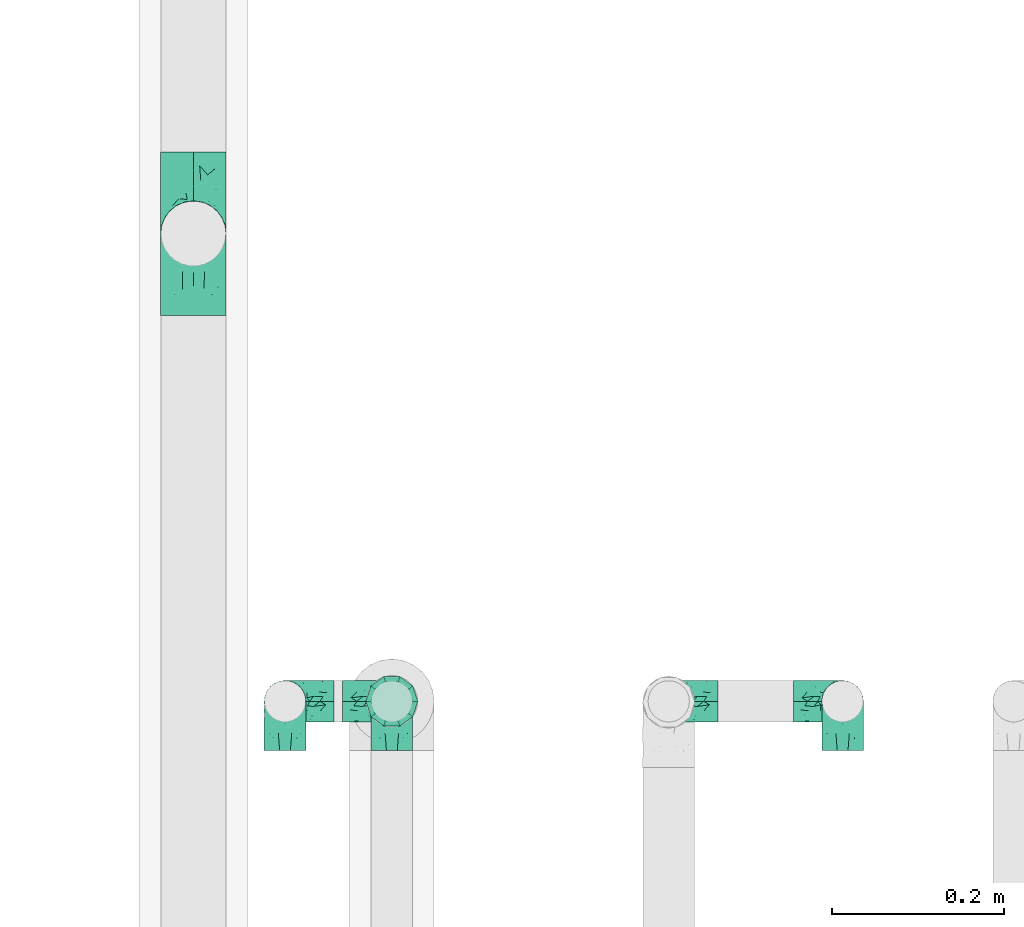
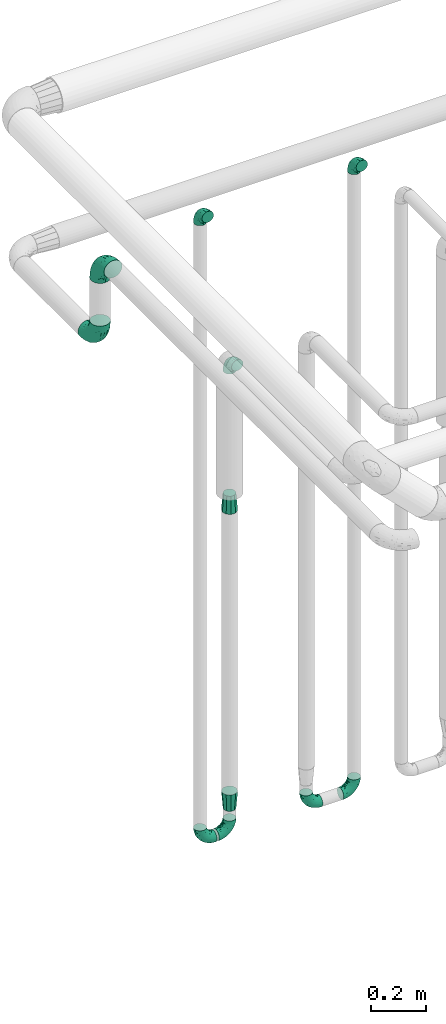
# One storey, part 697 of 827: 11 flow fittings.
"""IFC2X3 building model written with IfcOpenShell, lengths in millimetres."""

import ifcopenshell
import ifcopenshell.guid

model = None  # the IFC model being written
_history = None  # IfcOwnerHistory: only IFC2X3 demands one
_inside = {}  # id of a spatial element -> (the spatial element, [elements in it])
_under = {}  # id of a project, library or spatial element -> (it, [spatial elements below it])
_declared = {}  # id of a project -> (the project, [libraries it declares])
_typed = {}  # id of a type object -> (the type object, [elements of that type])
_made_of = {}  # id of a material, layer set ... -> (it, [elements and type objects made of it])


def new_model(schema):
    """Start an empty IFC model of exactly this schema.

    Asked for "IFC4X3", IfcOpenShell would pick the latest addendum, in which some entities
    have other attributes; the version numbers below select the first issue.
    IFC2X3 requires an IfcOwnerHistory on every rooted entity: one is made here for all.
    """
    global model, _history
    if schema == "IFC4X3":
        model = ifcopenshell.file(schema_version=(4, 3, 0, 0))
    else:
        model = ifcopenshell.file(schema=schema)
    _inside.clear()
    _under.clear()
    _declared.clear()
    _typed.clear()
    _made_of.clear()
    _history = None
    if model.schema == "IFC2X3":
        org = make("IfcOrganization", Name="unknown")
        user = make(
            "IfcPersonAndOrganization",
            ThePerson=make("IfcPerson", FamilyName="unknown"),
            TheOrganization=org,
        )
        app = make(
            "IfcApplication",
            ApplicationDeveloper=org,
            Version="unknown",
            ApplicationFullName="unknown",
            ApplicationIdentifier="unknown",
        )
        _history = make(
            "IfcOwnerHistory",
            OwningUser=user,
            OwningApplication=app,
            ChangeAction="ADDED",
            CreationDate=0,
        )
    return model


def make(cls, **values):
    """One entity of the class cls with the attributes given. An attribute that is None is left unset."""
    return model.create_entity(
        cls, **{name: value for name, value in values.items() if value is not None}
    )


def entity(cls, *values):
    """Any entity or typed value of the class cls, its attributes in the order of the schema. None: left unset."""
    e = model.create_entity(cls)
    for i, value in enumerate(values):
        if value is not None:
            e[i] = value
    return e


def rooted(cls, **values):
    """An entity with a GlobalId (a new one), such as an element, a storey or a relation."""
    return make(cls, GlobalId=ifcopenshell.guid.new(), OwnerHistory=_history, **values)


def si_unit(unit_type, name, prefix=None):
    """IfcSIUnit, for example si_unit("LENGTHUNIT", "METRE", prefix="MILLI")."""
    return make("IfcSIUnit", UnitType=unit_type, Prefix=prefix, Name=name)


def converted_unit(unit_type, name, factor, base, dimensions=None, offset=None):
    """IfcConversionBasedUnit, such as the inch: factor (a typed value) times the base unit."""
    return make(
        "IfcConversionBasedUnit"
        if offset is None
        else "IfcConversionBasedUnitWithOffset",
        ConversionOffset=offset,
        Dimensions=None
        if dimensions is None
        else entity("IfcDimensionalExponents", *dimensions),
        UnitType=unit_type,
        Name=name,
        ConversionFactor=make(
            "IfcMeasureWithUnit", ValueComponent=factor, UnitComponent=base
        ),
    )


def derived_unit(unit_type, elements):
    """IfcDerivedUnit: a product of units, each with its exponent."""
    return make(
        "IfcDerivedUnit",
        Elements=[
            make("IfcDerivedUnitElement", Unit=unit, Exponent=power)
            for unit, power in elements
        ],
        UnitType=unit_type,
    )


def assignment(units):
    """IfcUnitAssignment: the units of a project."""
    return None if units is None else make("IfcUnitAssignment", Units=units)


def point(xyz):
    """IfcCartesianPoint."""
    return None if xyz is None else make("IfcCartesianPoint", Coordinates=xyz)


def direction(xyz):
    """IfcDirection."""
    return None if xyz is None else make("IfcDirection", DirectionRatios=xyz)


def frame(location, z_axis=None, x_axis=None):
    """IfcAxis2Placement3D, a coordinate frame: its origin and axes. An axis left out is left unset."""
    return make(
        "IfcAxis2Placement3D",
        Location=point(location),
        Axis=direction(z_axis),
        RefDirection=direction(x_axis),
    )


def origin():
    """The frame at (0, 0, 0) with its axes left unset."""
    return frame((0.0, 0.0, 0.0))


def place(relative_to, where):
    """IfcLocalPlacement: puts the frame where relative to a parent placement (None: the world)."""
    return make(
        "IfcLocalPlacement", PlacementRelTo=relative_to, RelativePlacement=where
    )


def context(
    kind, dimensions, precision=None, world=None, true_north=None, identifier=None
):
    """IfcGeometricRepresentationContext, for example the 3D "Model" context."""
    return make(
        "IfcGeometricRepresentationContext",
        ContextIdentifier=identifier,
        ContextType=kind,
        CoordinateSpaceDimension=dimensions,
        Precision=precision,
        WorldCoordinateSystem=world,
        TrueNorth=true_north,
    )


def subcontext(parent, identifier, kind, view, scale=None):
    """IfcGeometricRepresentationSubContext, for example "Body" below "Model"."""
    return make(
        "IfcGeometricRepresentationSubContext",
        ContextIdentifier=identifier,
        ContextType=kind,
        ParentContext=parent,
        TargetScale=scale,
        TargetView=view,
    )


def project(units=None, contexts=None):
    """IfcProject with its units and contexts."""
    return rooted(
        "IfcProject",
        Name="project",
        RepresentationContexts=contexts,
        UnitsInContext=assignment(units),
    )


def spatial(cls, under=None, at=None, **own):
    """A site, building, storey or space (cls), placed at a placement, below another one or the project."""
    s = rooted(cls, ObjectPlacement=at, **own)
    if under is not None:
        _under.setdefault(under.id(), (under, []))[1].append(s)
    return s


def faces_of(points, faces, orient=None, outer=None):
    """IfcFace entities. A face is a list of loops; a loop is a list of indices into points, from 0.

    orient and outer hold one flag for each loop. By default every Orientation is true, the
    first loop of a face is its IfcFaceOuterBound and the others are IfcFaceBound.
    """
    made = []
    for i, loops in enumerate(faces):
        bounds = []
        for j, loop in enumerate(loops):
            is_outer = j == 0 if outer is None else outer[i][j]
            bounds.append(
                make(
                    "IfcFaceOuterBound" if is_outer else "IfcFaceBound",
                    Bound=make("IfcPolyLoop", Polygon=[points[k] for k in loop]),
                    Orientation=True if orient is None else orient[i][j],
                )
            )
        made.append(make("IfcFace", Bounds=bounds))
    return made


def faceted_brep(points, faces, orient=None, outer=None, voids=None):
    """IfcFacetedBrep: a solid bounded by flat faces; with voids (closed shells), ...WithVoids."""
    shared = [point(p) for p in points]
    hull = make("IfcClosedShell", CfsFaces=faces_of(shared, faces, orient, outer))
    if voids is None:
        return make("IfcFacetedBrep", Outer=hull)
    return make(
        "IfcFacetedBrepWithVoids",
        Outer=hull,
        Voids=[
            make(cls, CfsFaces=faces_of(shared, fs, o, b)) for cls, fs, o, b in voids
        ],
    )


def shape(context_of_items, identifier, shape_type, items):
    """IfcShapeRepresentation: the items that make up one representation, for example the "Body"."""
    return make(
        "IfcShapeRepresentation",
        ContextOfItems=context_of_items,
        RepresentationIdentifier=identifier,
        RepresentationType=shape_type,
        Items=items,
    )


def source(mapping_origin, context_of_items, identifier, shape_type, items):
    """IfcRepresentationMap: a shape defined once, which mapped items show again and again."""
    return make(
        "IfcRepresentationMap",
        MappingOrigin=mapping_origin,
        MappedRepresentation=shape(context_of_items, identifier, shape_type, items),
    )


def transform(
    local_origin,
    x_axis=None,
    y_axis=None,
    z_axis=None,
    scale=None,
    scale2=None,
    scale3=None,
    uniform=True,
):
    """IfcCartesianTransformationOperator3D, or its non-uniform kind. x_axis, y_axis, z_axis: its Axis1, 2, 3."""
    if uniform:
        return make(
            "IfcCartesianTransformationOperator3D",
            Axis1=direction(x_axis),
            Axis2=direction(y_axis),
            LocalOrigin=point(local_origin),
            Scale=scale,
            Axis3=direction(z_axis),
        )
    return make(
        "IfcCartesianTransformationOperator3DnonUniform",
        Axis1=direction(x_axis),
        Axis2=direction(y_axis),
        LocalOrigin=point(local_origin),
        Scale=scale,
        Axis3=direction(z_axis),
        Scale2=scale2,
        Scale3=scale3,
    )


def mapped(mapping_source, mapping_target):
    """IfcMappedItem: shows the shape of a source again, moved by a transform."""
    return make(
        "IfcMappedItem", MappingSource=mapping_source, MappingTarget=mapping_target
    )


def material(Name=None, Category=None):
    """IfcMaterial."""
    return make("IfcMaterial", Name=Name, Category=Category)


def made_of(thing, what):
    """Note that an element or type object is made of a material, layer set ...; save() writes the relation."""
    if what is not None:
        _made_of.setdefault(what.id(), (what, []))[1].append(thing)
    return thing


def type_object(cls, material=None, **own):
    """A type object (cls), such as IfcWallType, which elements share."""
    return made_of(rooted(cls, **own), material)


def type_shapes(of_type, sources):
    """Give a type object the sources (RepresentationMaps) that its elements show as mapped items."""
    of_type.RepresentationMaps = sources


def element(
    cls,
    number,
    at=None,
    inside=None,
    cuts=None,
    type_object=None,
    material=None,
    context=None,
    identifier="Body",
    shape_type=None,
    held_by="IfcProductDefinitionShape",
    body=None,
    shapes=None,
    **own,
):
    """One element of the class cls, such as IfcWall. Its Tag is "e" and its number.

    at: its placement. inside: the storey or other place that contains it. cuts: it is an
    opening in that element (IfcRelVoidsElement). A single representation is given by context,
    identifier, shape_type and body (its items); several are given by shapes. held_by: the class
    of the entity that holds the representations. save() writes the other relations.
    """
    e = rooted(cls, Tag="e%d" % number, ObjectPlacement=at, **own)
    if body is not None:
        shapes = [shape(context, identifier, shape_type, body)]
    if shapes is not None:
        e.Representation = make(held_by, Representations=shapes)
    if inside is not None:
        _inside.setdefault(inside.id(), (inside, []))[1].append(e)
    if cuts is not None:
        rooted(
            "IfcRelVoidsElement", RelatingBuildingElement=cuts, RelatedOpeningElement=e
        )
    if type_object is not None:
        _typed.setdefault(type_object.id(), (type_object, []))[1].append(e)
    return made_of(e, material)


def aggregate(whole, parts):
    """IfcRelAggregates: a whole, such as a stair, and the parts it consists of."""
    return rooted("IfcRelAggregates", RelatingObject=whole, RelatedObjects=parts)


def save(model, path):
    """Write the relations noted so far, then the file.

    IfcRelAggregates (storeys below a building ...), IfcRelContainedInSpatialStructure (elements
    in a storey), IfcRelDefinesByType, IfcRelAssociatesMaterial and IfcRelDeclares: one each for
    every whole, place, type object, material and project.
    """
    for whole, parts in _under.values():
        aggregate(whole, parts)
    for where, things in _inside.values():
        rooted(
            "IfcRelContainedInSpatialStructure",
            RelatedElements=things,
            RelatingStructure=where,
        )
    for kind, things in _typed.values():
        rooted("IfcRelDefinesByType", RelatedObjects=things, RelatingType=kind)
    for what, things in _made_of.values():
        rooted("IfcRelAssociatesMaterial", RelatedObjects=things, RelatingMaterial=what)
    for by, libraries in _declared.values():
        rooted("IfcRelDeclares", RelatingContext=by, RelatedDefinitions=libraries)
    model.write(path)


model = new_model("IFC2X3")

# Units and contexts
model_context = context("Model", 3, precision=0.01, world=origin(), true_north=direction((6.12303176911189e-17, 1.0)))
body_context = subcontext(model_context, "Body", "Model", "MODEL_VIEW")
ifc_project = project(units=[si_unit("LENGTHUNIT", "METRE", prefix="MILLI"), si_unit("AREAUNIT", "SQUARE_METRE"), si_unit("VOLUMEUNIT", "CUBIC_METRE"), converted_unit("PLANEANGLEUNIT", "DEGREE", entity("IfcRatioMeasure", 0.0174532925199433), si_unit("PLANEANGLEUNIT", "RADIAN"), dimensions=[0, 0, 0, 0, 0, 0, 0]), si_unit("MASSUNIT", "GRAM", prefix="KILO"), derived_unit("MASSDENSITYUNIT", [(si_unit("MASSUNIT", "GRAM", prefix="KILO"), 1), (si_unit("LENGTHUNIT", "METRE"), -3)]), derived_unit("MOMENTOFINERTIAUNIT", [(si_unit("LENGTHUNIT", "METRE"), 4)]), si_unit("TIMEUNIT", "SECOND"), si_unit("FREQUENCYUNIT", "HERTZ"), si_unit("THERMODYNAMICTEMPERATUREUNIT", "DEGREE_CELSIUS"), derived_unit("THERMALTRANSMITTANCEUNIT", [(si_unit("MASSUNIT", "GRAM", prefix="KILO"), 1), (si_unit("THERMODYNAMICTEMPERATUREUNIT", "KELVIN"), -1), (si_unit("TIMEUNIT", "SECOND"), -3)]), derived_unit("VOLUMETRICFLOWRATEUNIT", [(si_unit("LENGTHUNIT", "METRE"), 3), (si_unit("TIMEUNIT", "SECOND"), -1)]), derived_unit("MASSFLOWRATEUNIT", [(si_unit("MASSUNIT", "GRAM", prefix="KILO"), 1), (si_unit("TIMEUNIT", "SECOND"), -1)]), derived_unit("ROTATIONALFREQUENCYUNIT", [(si_unit("TIMEUNIT", "SECOND"), -1)]), si_unit("ELECTRICCURRENTUNIT", "AMPERE"), si_unit("ELECTRICVOLTAGEUNIT", "VOLT"), si_unit("POWERUNIT", "WATT"), si_unit("FORCEUNIT", "NEWTON", prefix="KILO"), si_unit("ILLUMINANCEUNIT", "LUX"), si_unit("LUMINOUSFLUXUNIT", "LUMEN"), si_unit("LUMINOUSINTENSITYUNIT", "CANDELA"), derived_unit("USERDEFINED", [(si_unit("MASSUNIT", "GRAM", prefix="KILO"), -1), (si_unit("LENGTHUNIT", "METRE"), -2), (si_unit("TIMEUNIT", "SECOND"), 3), (si_unit("LUMINOUSFLUXUNIT", "LUMEN"), 1)]), derived_unit("LINEARVELOCITYUNIT", [(si_unit("LENGTHUNIT", "METRE"), 1), (si_unit("TIMEUNIT", "SECOND"), -1)]), si_unit("PRESSUREUNIT", "PASCAL"), derived_unit("USERDEFINED", [(si_unit("LENGTHUNIT", "METRE"), -2), (si_unit("MASSUNIT", "GRAM", prefix="KILO"), 1), (si_unit("TIMEUNIT", "SECOND"), -2)]), derived_unit("LINEARFORCEUNIT", [(si_unit("MASSUNIT", "GRAM", prefix="KILO"), 1), (si_unit("LENGTHUNIT", "METRE"), 1), (si_unit("TIMEUNIT", "SECOND"), -2), (si_unit("LENGTHUNIT", "METRE"), -1)]), derived_unit("PLANARFORCEUNIT", [(si_unit("MASSUNIT", "GRAM", prefix="KILO"), 1), (si_unit("LENGTHUNIT", "METRE"), 1), (si_unit("TIMEUNIT", "SECOND"), -2), (si_unit("LENGTHUNIT", "METRE"), -2)])], contexts=[model_context])

# Site, building, storey
site_placement = place(None, origin())
site = spatial("IfcSite", under=ifc_project, at=site_placement, CompositionType="ELEMENT")
building_placement = place(site_placement, origin())
building = spatial("IfcBuilding", under=site, at=building_placement, CompositionType="ELEMENT")
storey_placement = place(building_placement, frame((0.0, 0.0, 28200.0)))
storey = spatial("IfcBuildingStorey", under=building, at=storey_placement, Name="08", CompositionType="ELEMENT", Elevation=28200.0)

# Flow fittings
ifc_material = material()
pipe_fitting_type_1 = type_object("IfcPipeFittingType", Name="ADSK_1", PredefinedType="NOTDEFINED", material=ifc_material)
shared_shape_1 = source(origin(), body_context, "Body", "Brep", [
    faceted_brep([(-57.0, 12.07, -20.91), (-57.0, 6.25, -23.33), (-57.0, 0.0, -24.15), (-57.0, -6.25, -23.33), (-57.0, -12.08, -20.91), (-57.0, -17.08, -17.08), (-57.0, -20.91, -12.08), (-57.0, -23.33, -6.25), (-57.0, -24.15, 0.0), (-57.0, -23.33, 6.25), (-57.0, -20.91, 12.07), (-57.0, -17.08, 17.08), (-57.0, -12.08, 20.91), (-57.0, -6.25, 23.33), (-57.0, 0.0, 24.15), (-57.0, 6.25, 23.33), (-57.0, 12.07, 20.91), (-57.0, 17.08, 17.08), (-57.0, 20.91, 12.07), (-57.0, 23.33, 6.25), (-57.0, 24.15, 0.0), (-57.0, 23.33, -6.25), (-57.0, 20.91, -12.08), (-57.0, 17.08, -17.08), (0.0, 57.0, -24.15), (-6.25, 57.0, -23.33), (-12.07, 57.0, -20.91), (-17.08, 57.0, -17.08), (-20.91, 57.0, -12.08), (-23.33, 57.0, -6.25), (-24.15, 57.0, 0.0), (-23.33, 57.0, 6.25), (-20.91, 57.0, 12.07), (-17.08, 57.0, 17.08), (-12.07, 57.0, 20.91), (-6.25, 57.0, 23.33), (0.0, 57.0, 24.15), (6.25, 57.0, 23.33), (12.08, 57.0, 20.91), (17.08, 57.0, 17.08), (20.91, 57.0, 12.07), (23.33, 57.0, 6.25), (24.15, 57.0, 0.0), (23.33, 57.0, -6.25), (20.91, 57.0, -12.08), (17.08, 57.0, -17.08), (12.08, 57.0, -20.91), (6.25, 57.0, -23.33), (14.9, 21.14, 6.17), (13.61, 24.64, 12.48), (6.23, 8.95, 8.98), (-41.47, -21.06, 0.0), (-41.92, -18.38, 13.72), (-24.64, -13.61, 12.48), (-37.37, -13.24, 18.15), (-6.8, -4.93, 8.18), (-21.76, -15.19, 6.22), (-12.78, -9.18, 0.0), (-37.73, -20.51, 7.75), (-7.38, 7.38, 20.24), (-23.37, -4.26, 20.42), (-11.9, -3.19, 15.86), (-42.14, -8.7, 21.82), (13.24, 37.37, 18.15), (9.33, 23.53, 16.85), (4.26, 23.37, 20.42), (2.77, 10.92, 15.55), (-29.46, 0.91, 23.52), (-44.13, 20.56, 15.69), (-39.25, 26.33, 10.88), (-49.02, 22.92, 9.96), (-34.58, 23.87, 17.15), (-15.8, 6.8, 22.81), (-8.67, 20.47, 23.88), (-18.12, 12.9, 24.08), (-48.29, 14.92, 19.65), (-44.06, -2.85, 23.78), (-9.23, 48.95, 22.58), (-3.78, 42.74, 24.07), (-40.34, 4.26, 24.09), (-44.02, 26.14, 5.46), (-44.04, 9.88, 22.74), (-4.95, 16.87, 22.52), (-2.75, 1.43, 12.5), (-25.48, 40.98, 10.71), (20.51, 37.73, 7.75), (18.38, 41.92, 13.72), (8.7, 42.14, 21.82), (-25.95, -17.97, 0.0), (2.85, 44.06, 23.78), (21.06, 41.47, 0.0), (17.97, 25.95, 0.0), (-24.04, -9.27, 17.13), (-33.26, 33.26, 5.86), (-28.55, 40.57, 0.0), (-40.57, 28.55, 0.0), (-25.29, 47.19, 4.06), (-27.01, 31.1, 16.77), (-15.7, 43.95, 19.9), (-20.27, 45.22, 15.61), (-30.53, 31.98, 12.64), (-11.28, 38.33, 22.92), (-9.97, 27.88, 24.09), (-20.15, 30.26, 21.25), (-31.25, 11.75, 23.64), (-28.75, 7.23, 24.15), (-29.53, 18.06, 22.27), (-28.44, 24.21, 20.02), (-37.55, 17.7, 20.26), (-15.88, 29.25, 22.99), (-20.82, 20.82, 23.44), (-0.91, 29.46, 23.52), (-13.5, -7.67, 12.04), (1.49, 1.56, 5.16), (8.86, 10.35, 4.59), (0.38, -0.38, 0.0), (9.18, 12.78, 0.0), (-37.37, -13.24, -18.15), (8.86, 10.35, -4.59), (-45.22, 20.27, -15.61), (-43.95, 15.7, -19.9), (-38.33, 11.28, -22.92), (-48.95, 9.23, -22.58), (-47.19, 25.29, -4.06), (-33.26, 33.26, -5.86), (18.38, 41.92, -13.72), (-30.26, 20.15, -21.25), (2.85, 44.06, -23.78), (-4.26, 40.34, -24.09), (-40.98, 25.48, -10.71), (-41.92, -18.38, -13.72), (9.25, 23.5, -16.92), (4.26, 23.37, -20.42), (13.24, 37.37, -18.15), (-37.73, -20.51, -7.75), (-11.75, 31.25, -23.64), (-7.23, 28.75, -24.15), (-12.9, 18.12, -24.08), (8.7, 42.14, -21.82), (-44.06, -2.85, -23.78), (-6.8, 15.8, -22.81), (-20.47, 8.67, -23.88), (-24.64, -13.61, -12.48), (-42.74, 3.78, -24.07), (-18.06, 29.53, -22.27), (-24.21, 28.44, -20.02), (-27.88, 9.97, -24.09), (-31.1, 27.01, -16.77), (-26.14, 44.02, -5.46), (14.9, 21.14, -6.17), (20.51, 37.73, -7.75), (-9.88, 44.04, -22.74), (-20.56, 44.13, -15.69), (-21.76, -15.19, -6.22), (-13.5, -7.67, -12.04), (-24.14, -9.76, -16.74), (-11.9, -3.19, -15.86), (-14.92, 48.29, -19.65), (-23.37, -4.26, -20.42), (-0.91, 29.46, -23.52), (-26.33, 39.25, -10.88), (-23.87, 34.58, -17.15), (-42.14, -8.7, -21.82), (-22.92, 49.02, -9.96), (13.61, 24.64, -12.48), (-31.98, 30.53, -12.64), (-16.87, 4.95, -22.52), (-17.7, 37.55, -20.26), (-29.25, 15.88, -22.99), (-20.82, 20.82, -23.44), (-29.46, 0.91, -23.52), (-7.38, 7.38, -20.24), (2.77, 10.92, -15.55), (6.23, 8.95, -8.98), (-6.8, -4.93, -8.18), (-2.81, 1.41, -12.54), (1.49, 1.56, -5.16)], [[[0, 1, 2, 3, 4, 5, 6, 7, 8, 9, 10, 11, 12, 13, 14, 15, 16, 17, 18, 19, 20, 21, 22, 23]], [[24, 25, 26, 27, 28, 29, 30, 31, 32, 33, 34, 35, 36, 37, 38, 39, 40, 41, 42, 43, 44, 45, 46, 47]], [[48, 49, 50]], [[9, 8, 51]], [[52, 53, 54]], [[55, 56, 57]], [[10, 58, 52]], [[9, 58, 10]], [[59, 60, 61]], [[54, 12, 11]], [[54, 62, 12]], [[63, 39, 38]], [[64, 65, 66]], [[62, 60, 67]], [[68, 69, 70]], [[71, 69, 68]], [[72, 73, 74]], [[16, 75, 17]], [[13, 76, 14]], [[35, 77, 78]], [[14, 79, 15]], [[17, 68, 18]], [[14, 76, 79]], [[20, 19, 80]], [[70, 19, 18]], [[81, 15, 79]], [[15, 81, 16]], [[73, 72, 82]], [[66, 83, 50]], [[32, 31, 84]], [[85, 86, 49]], [[63, 87, 65]], [[56, 58, 88]], [[36, 89, 37]], [[85, 41, 40]], [[36, 35, 78]], [[90, 41, 85]], [[40, 39, 86]], [[12, 62, 13]], [[86, 85, 40]], [[48, 85, 49]], [[85, 91, 90]], [[87, 38, 37]], [[92, 60, 54]], [[80, 69, 93]], [[93, 94, 95]], [[10, 52, 11]], [[94, 96, 30]], [[97, 98, 99]], [[80, 93, 95]], [[100, 97, 84]], [[99, 98, 33]], [[101, 102, 78]], [[103, 101, 98]], [[96, 31, 30]], [[77, 98, 101]], [[77, 35, 34]], [[34, 33, 98]], [[9, 51, 58]], [[87, 63, 38]], [[104, 105, 74]], [[106, 103, 107]], [[106, 81, 104]], [[75, 68, 17]], [[108, 107, 71]], [[33, 32, 99]], [[109, 103, 110]], [[101, 109, 102]], [[89, 78, 111]], [[53, 52, 58]], [[54, 11, 52]], [[60, 62, 54]], [[88, 58, 51]], [[76, 62, 67]], [[53, 112, 92]], [[60, 59, 72]], [[39, 63, 86]], [[49, 86, 63]], [[89, 87, 37]], [[42, 41, 90]], [[111, 82, 65]], [[111, 65, 87]], [[65, 59, 66]], [[104, 81, 79]], [[75, 81, 108]], [[32, 84, 99]], [[97, 99, 84]], [[98, 97, 103]], [[106, 107, 108]], [[74, 102, 110]], [[111, 78, 102]], [[74, 110, 104]], [[74, 67, 72]], [[61, 92, 112]], [[66, 59, 61]], [[56, 53, 58]], [[66, 50, 49]], [[61, 112, 83]], [[66, 49, 64]], [[78, 89, 36]], [[87, 89, 111]], [[62, 76, 13]], [[79, 76, 67]], [[100, 93, 69]], [[96, 93, 84]], [[55, 113, 50]], [[113, 114, 50]], [[104, 79, 105]], [[106, 104, 110]], [[20, 80, 95]], [[85, 48, 91]], [[115, 114, 113]], [[116, 91, 48]], [[70, 80, 19]], [[93, 96, 94]], [[84, 31, 96]], [[103, 106, 110]], [[81, 106, 108]], [[103, 97, 107]], [[71, 107, 97]], [[71, 97, 100]], [[108, 71, 68]], [[79, 67, 105]], [[67, 74, 105]], [[115, 113, 57]], [[112, 56, 55]], [[56, 88, 57]], [[60, 72, 67]], [[82, 72, 59]], [[65, 82, 59]], [[82, 111, 73]], [[111, 102, 73]], [[102, 74, 73]], [[81, 75, 16]], [[68, 75, 108]], [[68, 70, 18]], [[80, 70, 69]], [[98, 77, 34]], [[78, 77, 101]], [[93, 100, 84]], [[71, 100, 69]], [[102, 109, 110]], [[101, 103, 109]], [[53, 92, 54]], [[61, 60, 92]], [[56, 112, 53]], [[83, 112, 55]], [[50, 83, 55]], [[61, 83, 66]], [[49, 63, 64]], [[65, 64, 63]], [[57, 113, 55]], [[114, 115, 116]], [[116, 48, 114]], [[48, 50, 114]], [[117, 5, 4]], [[116, 115, 118]], [[119, 120, 23]], [[121, 122, 120]], [[95, 123, 20]], [[0, 23, 120]], [[124, 95, 94]], [[125, 45, 44]], [[121, 120, 126]], [[24, 127, 128]], [[22, 21, 129]], [[0, 122, 1]], [[5, 117, 130]], [[131, 132, 133]], [[134, 88, 51]], [[135, 136, 137]], [[6, 5, 130]], [[46, 138, 47]], [[139, 3, 2]], [[140, 141, 137]], [[6, 134, 7]], [[134, 130, 142]], [[143, 2, 1]], [[144, 126, 145]], [[121, 146, 143]], [[147, 120, 119]], [[94, 148, 124]], [[149, 150, 91]], [[30, 29, 148]], [[151, 25, 128]], [[27, 152, 28]], [[134, 153, 88]], [[154, 155, 156]], [[27, 26, 157]], [[151, 26, 25]], [[155, 158, 156]], [[24, 47, 127]], [[1, 122, 143]], [[138, 132, 159]], [[160, 152, 161]], [[24, 128, 25]], [[46, 133, 138]], [[162, 117, 4]], [[148, 160, 124]], [[152, 160, 163]], [[154, 142, 155]], [[45, 125, 133]], [[133, 46, 45]], [[125, 164, 133]], [[51, 7, 134]], [[42, 90, 43]], [[165, 147, 129]], [[153, 134, 142]], [[43, 150, 44]], [[162, 4, 3]], [[141, 140, 166]], [[117, 162, 158]], [[163, 29, 28]], [[43, 90, 150]], [[123, 21, 20]], [[144, 151, 135]], [[157, 152, 27]], [[167, 145, 161]], [[23, 22, 119]], [[168, 126, 169]], [[121, 168, 146]], [[139, 143, 170]], [[142, 130, 117]], [[8, 7, 51]], [[134, 6, 130]], [[139, 162, 3]], [[170, 166, 158]], [[170, 158, 162]], [[158, 171, 156]], [[44, 150, 125]], [[91, 150, 90]], [[164, 125, 150]], [[132, 138, 133]], [[127, 138, 159]], [[131, 164, 172]], [[132, 171, 140]], [[135, 151, 128]], [[157, 151, 167]], [[22, 129, 119]], [[147, 119, 129]], [[120, 147, 126]], [[144, 145, 167]], [[137, 146, 169]], [[170, 143, 146]], [[137, 169, 135]], [[137, 159, 140]], [[171, 172, 156]], [[173, 174, 175]], [[156, 175, 154]], [[174, 57, 153]], [[132, 172, 171]], [[172, 164, 173]], [[143, 139, 2]], [[162, 139, 170]], [[138, 127, 47]], [[128, 127, 159]], [[165, 124, 160]], [[123, 124, 129]], [[149, 173, 164]], [[176, 174, 173]], [[135, 128, 136]], [[144, 135, 169]], [[150, 149, 164]], [[176, 118, 115]], [[149, 91, 116]], [[30, 148, 94]], [[163, 148, 29]], [[124, 123, 95]], [[129, 21, 123]], [[126, 144, 169]], [[151, 144, 167]], [[126, 147, 145]], [[161, 145, 147]], [[161, 147, 165]], [[167, 161, 152]], [[128, 159, 136]], [[159, 137, 136]], [[154, 153, 142]], [[132, 140, 159]], [[174, 176, 57]], [[57, 88, 153]], [[166, 140, 171]], [[158, 166, 171]], [[166, 170, 141]], [[170, 146, 141]], [[146, 137, 141]], [[151, 157, 26]], [[152, 157, 167]], [[152, 163, 28]], [[148, 163, 160]], [[120, 122, 0]], [[143, 122, 121]], [[124, 165, 129]], [[161, 165, 160]], [[146, 168, 169]], [[121, 126, 168]], [[142, 117, 155]], [[158, 155, 117]], [[175, 156, 172]], [[153, 154, 174]], [[173, 175, 172]], [[174, 154, 175]], [[164, 131, 133]], [[172, 132, 131]], [[176, 173, 118]], [[57, 176, 115]], [[173, 149, 118]], [[149, 116, 118]]]),
])
type_shapes(pipe_fitting_type_1, [shared_shape_1])
for number, where, z_axis, x_axis, name in (
    (1, (52721.06, 17500.0, 400.0), (0.0, 1.0, 0.0), (0.0, 0.0, -1.0), "ADSK_1"),
    (2, (52519.38, 17500.0, 400.0), (0.0, 1.0, 0.0), (-1.0, 0.0, 0.0), "ADSK_1"),
    (3, (52721.06, 17500.0, 3200.0), (1.0, 0.0, 0.0), (0.0, 0.0, 1.0), "ADSK_1"),
    (4, (52198.28, 17500.0, 400.0), (0.0, 1.0, 0.0), (0.0, 0.0, -1.0), "ADSK_1"),
    (5, (52074.38, 17500.0, 400.0), (0.0, 1.0, 0.0), (-1.0, 0.0, 0.0), "ADSK_1"),
    (6, (52198.28, 17500.0, 2498.17), (1.0, 0.0, 0.0), (0.0, 0.0, 1.0), "ADSK_1"),
    (7, (52074.38, 17500.0, 3200.0), (1.0, 0.0, 0.0), (0.0, 0.0, 1.0), "ADSK_1"),
):
    element("IfcFlowFitting", number, at=place(storey_placement, frame(where, z_axis=z_axis, x_axis=x_axis)), inside=storey, type_object=pipe_fitting_type_1, material=ifc_material, Name=name, ObjectType="ADSK_1", context=body_context, shape_type="MappedRepresentation", body=[
        mapped(shared_shape_1, transform((0.0, 0.0, 0.0), scale=1.0)),
    ])
pipe_fitting_type_2 = type_object("IfcPipeFittingType", Name="ADSK_1", PredefinedType="NOTDEFINED", material=ifc_material)
shared_shape_2 = source(origin(), body_context, "Body", "Brep", [
    faceted_brep([(-95.0, 19.02, -32.95), (-95.0, 9.85, -36.75), (-95.0, 0.0, -38.05), (-95.0, -9.85, -36.75), (-95.0, -19.03, -32.95), (-95.0, -26.91, -26.91), (-95.0, -32.95, -19.03), (-95.0, -36.75, -9.85), (-95.0, -38.05, 0.0), (-95.0, -36.75, 9.85), (-95.0, -32.95, 19.02), (-95.0, -26.91, 26.91), (-95.0, -19.03, 32.95), (-95.0, -9.85, 36.75), (-95.0, 0.0, 38.05), (-95.0, 9.85, 36.75), (-95.0, 19.02, 32.95), (-95.0, 26.91, 26.91), (-95.0, 32.95, 19.02), (-95.0, 36.75, 9.85), (-95.0, 38.05, 0.0), (-95.0, 36.75, -9.85), (-95.0, 32.95, -19.03), (-95.0, 26.91, -26.91), (0.0, 95.0, -38.05), (-9.85, 95.0, -36.75), (-19.02, 95.0, -32.95), (-26.91, 95.0, -26.91), (-32.95, 95.0, -19.03), (-36.75, 95.0, -9.85), (-38.05, 95.0, 0.0), (-36.75, 95.0, 9.85), (-32.95, 95.0, 19.02), (-26.91, 95.0, 26.91), (-19.02, 95.0, 32.95), (-9.85, 95.0, 36.75), (0.0, 95.0, 38.05), (9.85, 95.0, 36.75), (19.03, 95.0, 32.95), (26.91, 95.0, 26.91), (32.95, 95.0, 19.02), (36.75, 95.0, 9.85), (38.05, 95.0, 0.0), (36.75, 95.0, -9.85), (32.95, 95.0, -19.03), (26.91, 95.0, -26.91), (19.03, 95.0, -32.95), (9.85, 95.0, -36.75), (-7.99, -4.96, 6.3), (-0.92, 0.92, 0.0), (4.62, 8.1, 8.01), (-76.19, -35.57, 0.0), (-64.32, -32.32, 12.43), (20.51, 62.45, 28.68), (-60.56, -33.52, 0.0), (-70.4, -13.47, 34.42), (-39.61, -5.88, 32.32), (-49.6, 2.07, 37.1), (-70.34, -28.81, 21.71), (14.64, 40.81, 26.5), (5.88, 39.61, 32.32), (3.59, 20.77, 25.31), (-40.45, 68.06, 16.75), (-62.45, -20.51, 28.68), (-44.52, -26.87, 0.0), (-28.47, -20.22, 0.0), (-26.43, -17.83, 8.75), (-76.1, 39.63, 10.76), (-72.74, 37.58, 18.19), (-60.35, 46.18, 14.61), (-13.4, 13.4, 32.12), (-20.77, -3.59, 25.31), (-14.66, 81.47, 35.56), (-6.22, 71.26, 37.92), (-57.5, 42.48, 22.79), (-15.0, 34.74, 37.7), (-27.1, 12.08, 36.05), (-9.2, 28.81, 35.63), (-79.98, 23.7, 30.95), (-73.68, -4.3, 37.48), (-30.74, 21.67, 37.97), (-62.36, 47.59, 6.79), (-72.71, 32.83, 24.69), (-67.42, 7.02, 37.95), (-32.13, 75.27, 24.51), (-43.46, 51.47, 26.26), (-24.98, 73.15, 31.29), (20.59, 41.28, 19.85), (7.79, 16.09, 15.86), (-73.21, 42.39, 0.0), (-54.73, 54.73, 0.0), (-73.44, 15.79, 35.79), (-5.94, 4.32, 20.43), (28.81, 70.34, 21.71), (32.32, 64.32, 12.43), (-53.59, 26.2, 35.09), (-52.02, 19.31, 37.21), (21.38, 33.53, 10.34), (26.87, 44.52, 0.0), (-48.28, 12.14, 38.05), (4.3, 73.68, 37.48), (-44.08, -25.52, 12.79), (-41.28, -20.59, 19.85), (35.57, 76.19, 0.0), (-47.26, 54.3, 20.18), (-47.4, 61.99, 8.58), (-42.39, 73.21, 0.0), (-39.67, 78.86, 7.21), (-45.69, 36.84, 33.11), (-32.83, 50.13, 33.35), (13.47, 70.4, 34.42), (-18.25, 63.73, 36.07), (-40.63, -13.75, 27.22), (-16.63, 46.37, 37.95), (-53.47, 38.79, 28.59), (-26.07, 48.54, 36.15), (-34.51, 34.51, 36.86), (-2.07, 49.6, 37.1), (-22.79, -10.49, 19.23), (-61.73, 28.67, 31.87), (9.65, 14.7, 0.0), (20.22, 28.47, 0.0), (33.52, 60.56, 0.0), (-11.42, -5.44, 13.25), (-14.7, -9.65, 0.0), (-81.47, 14.66, -35.56), (-62.45, -20.51, -28.68), (-71.26, 6.22, -37.92), (-75.27, 32.13, -24.51), (-73.15, 24.98, -31.29), (13.47, 70.4, -34.42), (5.88, 39.61, -32.32), (-2.07, 49.6, -37.1), (-78.86, 39.67, -7.21), (-70.4, -13.47, -34.42), (-39.61, -5.88, -32.32), (-61.99, 47.4, -8.58), (32.32, 64.32, -12.43), (28.81, 70.34, -21.71), (-63.73, 18.25, -36.07), (-50.13, 32.83, -33.35), (4.3, 73.68, -37.48), (-7.02, 67.42, -37.95), (-39.63, 76.1, -10.76), (-46.18, 60.35, -14.61), (-47.59, 62.36, -6.79), (-64.32, -32.32, -12.43), (-26.2, 53.59, -35.09), (-15.79, 73.44, -35.79), (-19.31, 52.02, -37.21), (-37.58, 72.74, -18.19), (-70.34, -28.81, -21.71), (-42.48, 57.5, -22.79), (-38.79, 53.47, -28.59), (-51.47, 43.46, -26.26), (-32.83, 72.71, -24.69), (-46.37, 16.63, -37.95), (-73.68, -4.3, -37.48), (-41.28, -20.59, -19.85), (-44.08, -25.52, -12.79), (13.75, 40.63, -27.22), (20.51, 62.45, -28.68), (-68.06, 40.45, -16.75), (-54.3, 47.26, -20.18), (-12.14, 48.28, -38.05), (-21.67, 30.74, -37.97), (-36.84, 45.69, -33.11), (-11.42, -5.44, -13.25), (7.79, 16.09, -15.86), (4.62, 8.1, -8.01), (-23.7, 79.98, -30.95), (-26.43, -17.83, -8.75), (-7.99, -4.96, -6.3), (-40.81, -14.64, -26.5), (-20.77, -3.59, -25.31), (-34.74, 15.0, -37.7), (-12.08, 27.1, -36.05), (-28.81, 9.2, -35.63), (-22.79, -10.49, -19.23), (21.38, 33.53, -10.34), (20.59, 41.28, -19.85), (-48.54, 26.07, -36.15), (-49.6, 2.07, -37.1), (-13.4, 13.4, -32.12), (3.59, 20.77, -25.31), (-28.67, 61.73, -31.87), (-34.51, 34.51, -36.86), (-5.94, 4.32, -20.43)], [[[0, 1, 2, 3, 4, 5, 6, 7, 8, 9, 10, 11, 12, 13, 14, 15, 16, 17, 18, 19, 20, 21, 22, 23]], [[24, 25, 26, 27, 28, 29, 30, 31, 32, 33, 34, 35, 36, 37, 38, 39, 40, 41, 42, 43, 44, 45, 46, 47]], [[48, 49, 50]], [[51, 52, 9]], [[53, 39, 38]], [[9, 52, 10]], [[54, 52, 51]], [[55, 56, 57]], [[11, 10, 58]], [[59, 60, 61]], [[32, 31, 62]], [[63, 12, 11]], [[63, 55, 12]], [[64, 65, 66]], [[67, 68, 69]], [[70, 56, 71]], [[35, 72, 73]], [[69, 68, 74]], [[75, 76, 77]], [[16, 78, 17]], [[13, 79, 14]], [[76, 75, 80]], [[67, 69, 81]], [[18, 17, 82]], [[14, 79, 83]], [[20, 19, 67]], [[84, 85, 86]], [[87, 61, 88]], [[89, 81, 90]], [[18, 82, 68]], [[15, 91, 16]], [[14, 83, 15]], [[71, 92, 61]], [[17, 78, 82]], [[93, 87, 94]], [[95, 91, 96]], [[97, 98, 94]], [[86, 72, 34]], [[96, 99, 80]], [[37, 36, 100]], [[40, 39, 93]], [[40, 94, 41]], [[64, 66, 101]], [[93, 94, 40]], [[58, 102, 63]], [[94, 103, 41]], [[94, 87, 97]], [[104, 69, 74]], [[34, 33, 86]], [[105, 69, 104]], [[52, 58, 10]], [[106, 107, 30]], [[108, 109, 85]], [[105, 106, 90]], [[53, 110, 60]], [[86, 111, 72]], [[86, 109, 111]], [[33, 84, 86]], [[12, 55, 13]], [[112, 56, 63]], [[110, 38, 37]], [[34, 72, 35]], [[36, 35, 73]], [[111, 113, 73]], [[105, 107, 106]], [[110, 53, 38]], [[74, 114, 85]], [[91, 15, 83]], [[105, 90, 81]], [[107, 62, 31]], [[33, 32, 84]], [[115, 109, 116]], [[111, 115, 113]], [[100, 73, 117]], [[56, 55, 63]], [[79, 55, 57]], [[102, 118, 112]], [[56, 70, 76]], [[100, 110, 37]], [[117, 77, 60]], [[117, 60, 110]], [[60, 70, 61]], [[58, 52, 101]], [[63, 11, 58]], [[39, 53, 93]], [[87, 93, 53]], [[96, 91, 83]], [[78, 91, 119]], [[32, 62, 84]], [[84, 62, 104]], [[86, 85, 109]], [[85, 114, 108]], [[80, 113, 116]], [[117, 73, 113]], [[80, 116, 96]], [[80, 57, 76]], [[71, 112, 118]], [[61, 87, 59]], [[62, 107, 105]], [[97, 120, 121]], [[70, 71, 61]], [[71, 118, 92]], [[73, 100, 36]], [[110, 100, 117]], [[55, 79, 13]], [[83, 79, 57]], [[96, 83, 99]], [[116, 108, 95]], [[50, 97, 88]], [[97, 87, 88]], [[50, 49, 120]], [[122, 94, 98]], [[89, 20, 67]], [[105, 81, 69]], [[89, 67, 81]], [[68, 19, 18]], [[68, 67, 19]], [[74, 68, 82]], [[114, 82, 119]], [[74, 85, 104]], [[82, 114, 74]], [[114, 119, 108]], [[95, 108, 119]], [[116, 109, 108]], [[123, 48, 50]], [[97, 50, 120]], [[123, 50, 88]], [[91, 95, 119]], [[116, 95, 96]], [[84, 104, 85]], [[104, 62, 105]], [[83, 57, 99]], [[57, 80, 99]], [[66, 48, 123]], [[66, 124, 48]], [[118, 66, 123]], [[124, 66, 65]], [[66, 118, 101]], [[54, 64, 52]], [[124, 49, 48]], [[30, 107, 31]], [[91, 78, 16]], [[82, 78, 119]], [[56, 76, 57]], [[77, 76, 70]], [[60, 77, 70]], [[77, 117, 75]], [[117, 113, 75]], [[113, 80, 75]], [[9, 8, 51]], [[103, 94, 122]], [[103, 42, 41]], [[73, 72, 111]], [[113, 115, 116]], [[111, 109, 115]], [[102, 112, 63]], [[71, 56, 112]], [[118, 102, 101]], [[92, 123, 88]], [[123, 92, 118]], [[61, 92, 88]], [[87, 53, 59]], [[60, 59, 53]], [[97, 121, 98]], [[58, 101, 102]], [[64, 101, 52]], [[125, 1, 0]], [[126, 5, 4]], [[2, 1, 127]], [[1, 125, 127]], [[128, 129, 23]], [[130, 131, 132]], [[89, 133, 20]], [[126, 134, 135]], [[136, 89, 90]], [[137, 138, 44]], [[139, 129, 140]], [[24, 141, 142]], [[143, 144, 145]], [[125, 129, 139]], [[6, 146, 7]], [[147, 148, 149]], [[146, 51, 7]], [[143, 150, 144]], [[146, 6, 151]], [[152, 153, 154]], [[126, 4, 134]], [[0, 23, 129]], [[28, 155, 150]], [[43, 42, 103]], [[54, 146, 64]], [[139, 156, 127]], [[157, 3, 2]], [[151, 158, 159]], [[160, 131, 161]], [[22, 21, 162]], [[136, 144, 163]], [[149, 164, 165]], [[24, 142, 25]], [[166, 140, 154]], [[154, 129, 128]], [[143, 30, 29]], [[167, 168, 169]], [[155, 28, 27]], [[26, 170, 27]], [[171, 167, 172]], [[26, 25, 148]], [[27, 170, 155]], [[173, 135, 174]], [[144, 150, 152]], [[175, 176, 177]], [[24, 47, 141]], [[45, 161, 46]], [[148, 25, 142]], [[176, 175, 165]], [[64, 159, 171]], [[138, 45, 44]], [[130, 46, 161]], [[137, 44, 43]], [[178, 159, 158]], [[137, 103, 122]], [[163, 144, 152]], [[136, 133, 89]], [[103, 137, 43]], [[6, 5, 151]], [[178, 158, 173]], [[134, 4, 3]], [[178, 173, 174]], [[137, 98, 179]], [[145, 90, 106]], [[138, 180, 161]], [[46, 130, 47]], [[136, 90, 145]], [[133, 162, 21]], [[23, 22, 128]], [[139, 140, 181]], [[139, 181, 156]], [[157, 127, 182]], [[157, 134, 3]], [[182, 177, 135]], [[182, 135, 134]], [[135, 183, 174]], [[131, 130, 161]], [[141, 130, 132]], [[160, 180, 184]], [[131, 183, 176]], [[5, 126, 151]], [[158, 151, 126]], [[180, 138, 137]], [[161, 45, 138]], [[149, 148, 142]], [[170, 148, 185]], [[22, 162, 128]], [[128, 162, 163]], [[129, 154, 140]], [[154, 153, 166]], [[165, 156, 186]], [[182, 127, 156]], [[165, 186, 149]], [[165, 132, 176]], [[131, 184, 183]], [[187, 167, 178]], [[184, 168, 187]], [[167, 169, 172]], [[184, 180, 168]], [[174, 183, 184]], [[127, 157, 2]], [[134, 157, 182]], [[130, 141, 47]], [[142, 141, 132]], [[149, 142, 164]], [[186, 166, 147]], [[180, 179, 168]], [[169, 179, 120]], [[137, 179, 180]], [[179, 121, 120]], [[106, 30, 143]], [[136, 145, 144]], [[106, 143, 145]], [[150, 29, 28]], [[150, 143, 29]], [[152, 150, 155]], [[153, 155, 185]], [[152, 154, 163]], [[155, 153, 152]], [[153, 185, 166]], [[147, 166, 185]], [[186, 140, 166]], [[169, 120, 49]], [[169, 49, 172]], [[179, 169, 168]], [[148, 147, 185]], [[186, 147, 149]], [[128, 163, 154]], [[163, 162, 136]], [[142, 132, 164]], [[132, 165, 164]], [[171, 124, 65]], [[124, 171, 172]], [[64, 146, 159]], [[171, 159, 178]], [[171, 65, 64]], [[172, 49, 124]], [[162, 133, 136]], [[20, 133, 21]], [[148, 170, 26]], [[155, 170, 185]], [[131, 176, 132]], [[177, 176, 183]], [[135, 177, 183]], [[177, 182, 175]], [[182, 156, 175]], [[156, 165, 175]], [[51, 146, 54]], [[51, 8, 7]], [[129, 125, 0]], [[127, 125, 139]], [[140, 186, 181]], [[156, 181, 186]], [[158, 126, 173]], [[135, 173, 126]], [[187, 178, 174]], [[171, 178, 167]], [[184, 187, 174]], [[167, 187, 168]], [[180, 160, 161]], [[184, 131, 160]], [[98, 137, 122]], [[98, 121, 179]], [[151, 159, 146]]]),
])
type_shapes(pipe_fitting_type_2, [shared_shape_2])
for number, where, z_axis, x_axis, name in (
    (8, (51968.1, 18042.38, 2700.0), (-1.0, 0.0, 0.0), (0.0, 1.0, 0.0), "ADSK_1"),
    (9, (51968.1, 18042.38, 2320.0), (1.0, 0.0, 0.0), (0.0, 0.0, -1.0), "ADSK_1"),
):
    element("IfcFlowFitting", number, at=place(storey_placement, frame(where, z_axis=z_axis, x_axis=x_axis)), inside=storey, type_object=pipe_fitting_type_2, material=ifc_material, Name=name, ObjectType="ADSK_1", context=body_context, shape_type="MappedRepresentation", body=[
        mapped(shared_shape_2, transform((0.0, 0.0, 0.0), scale=1.0)),
    ])
pipe_fitting_type_3 = type_object("IfcPipeFittingType", Name="ADSK_1", PredefinedType="NOTDEFINED", material=ifc_material)
shared_shape_3 = source(origin(), body_context, "Body", "Brep", [
    faceted_brep([(76.0, 24.15, 0.0), (76.0, 21.84, 7.1), (76.0, 19.54, 14.2), (76.0, 13.5, 18.58), (76.0, 7.46, 22.97), (76.0, 0.0, 22.97), (76.0, -7.46, 22.97), (76.0, -13.5, 18.58), (76.0, -19.54, 14.2), (76.0, -21.84, 7.1), (76.0, -24.15, 0.0), (76.0, -21.84, -7.1), (76.0, -19.54, -14.2), (76.0, -13.5, -18.58), (76.0, -7.46, -22.97), (76.0, 0.0, -22.97), (76.0, 7.46, -22.97), (76.0, 13.5, -18.58), (76.0, 19.54, -14.2), (76.0, 21.84, -7.1), (0.0, -30.15, 0.0), (0.0, -27.27, 8.86), (0.0, -24.39, 17.72), (0.0, -16.85, 23.2), (0.0, -9.32, 28.67), (0.0, 0.0, 28.67), (0.0, 9.32, 28.67), (0.0, 16.85, 23.2), (0.0, 24.39, 17.72), (0.0, 26.33, 11.75), (0.0, 28.24, 5.87), (0.0, 30.15, 0.0), (0.0, 27.27, -8.86), (0.0, 24.39, -17.72), (0.0, 16.85, -23.2), (0.0, 9.32, -28.67), (0.0, 0.0, -28.67), (0.0, -9.32, -28.67), (0.0, -16.85, -23.2), (0.0, -24.39, -17.72), (0.0, -26.33, -11.75), (0.0, -28.24, -5.87)], [[[0, 1, 2, 3, 4, 5, 6, 7, 8, 9, 10, 11, 12, 13, 14, 15, 16, 17, 18, 19]], [[20, 21, 22, 23, 24, 25, 26, 27, 28, 29, 30, 31, 32, 33, 34, 35, 36, 37, 38, 39, 40, 41]], [[19, 18, 33, 32, 31, 0]], [[36, 35, 16, 15, 14, 37]], [[35, 34, 33, 18, 17, 16]], [[41, 40, 39, 12, 11, 10, 20]], [[14, 13, 12, 39, 38, 37]], [[9, 8, 22, 21, 20, 10]], [[25, 24, 6, 5, 4, 26]], [[24, 23, 22, 8, 7, 6]], [[30, 29, 28, 2, 1, 0, 31]], [[4, 3, 2, 28, 27, 26]]]),
])
type_shapes(pipe_fitting_type_3, [shared_shape_3])
flow_fitting_1_placement = place(storey_placement, frame((52198.28, 17500.0, 1822.17), z_axis=(0.0, 1.0, 0.0), x_axis=(0.0, 0.0, 1.0)))
element("IfcFlowFitting", 10, at=flow_fitting_1_placement, inside=storey, type_object=pipe_fitting_type_3, material=ifc_material, Name="ADSK_1", ObjectType="ADSK_1", context=body_context, shape_type="MappedRepresentation", body=[
    mapped(shared_shape_3, transform((0.0, 0.0, 0.0), scale=1.0)),
])
pipe_fitting_type_4 = type_object("IfcPipeFittingType", Name="ADSK_1", PredefinedType="NOTDEFINED", material=ifc_material)
shared_shape_4 = source(origin(), body_context, "Body", "Brep", [
    faceted_brep([(76.0, -30.15, 0.0), (76.0, -28.24, -5.87), (76.0, -26.33, -11.75), (76.0, -24.39, -17.72), (76.0, -16.85, -23.2), (76.0, -9.32, -28.67), (76.0, 0.0, -28.67), (76.0, 9.32, -28.67), (76.0, 16.85, -23.2), (76.0, 24.39, -17.72), (76.0, 26.33, -11.75), (76.0, 28.24, -5.87), (76.0, 30.15, 0.0), (76.0, 28.24, 5.87), (76.0, 26.33, 11.75), (76.0, 24.39, 17.72), (76.0, 16.85, 23.2), (76.0, 9.32, 28.67), (76.0, 0.0, 28.67), (76.0, -9.32, 28.67), (76.0, -16.85, 23.2), (76.0, -24.39, 17.72), (76.0, -26.33, 11.75), (76.0, -28.24, 5.87), (0.0, -19.54, -14.2), (0.0, -21.84, -7.1), (0.0, -24.15, 0.0), (0.0, -21.84, 7.1), (0.0, -19.54, 14.2), (0.0, -13.5, 18.58), (0.0, -7.46, 22.97), (0.0, 0.0, 22.97), (0.0, 7.46, 22.97), (0.0, 13.5, 18.58), (0.0, 19.54, 14.2), (0.0, 21.84, 7.1), (0.0, 24.15, 0.0), (0.0, 21.84, -7.1), (0.0, 19.54, -14.2), (0.0, 13.5, -18.58), (0.0, 7.46, -22.97), (0.0, 0.0, -22.97), (0.0, -7.46, -22.97), (0.0, -13.5, -18.58)], [[[0, 1, 2, 3, 4, 5, 6, 7, 8, 9, 10, 11, 12, 13, 14, 15, 16, 17, 18, 19, 20, 21, 22, 23]], [[24, 25, 26, 27, 28, 29, 30, 31, 32, 33, 34, 35, 36, 37, 38, 39, 40, 41, 42, 43]], [[24, 3, 2, 1, 0, 26, 25]], [[7, 40, 39, 38, 9, 8]], [[42, 5, 4, 3, 24, 43]], [[6, 5, 42, 41, 40, 7]], [[11, 10, 9, 38, 37, 36, 12]], [[34, 15, 14, 13, 12, 36, 35]], [[19, 30, 29, 28, 21, 20]], [[32, 17, 16, 15, 34, 33]], [[18, 17, 32, 31, 30, 19]], [[23, 22, 21, 28, 27, 26, 0]]]),
])
type_shapes(pipe_fitting_type_4, [shared_shape_4])
flow_fitting_2_placement = place(storey_placement, frame((52198.28, 17500.0, 500.0), z_axis=(0.0, 1.0, 0.0), x_axis=(0.0, 0.0, 1.0)))
element("IfcFlowFitting", 11, at=flow_fitting_2_placement, inside=storey, type_object=pipe_fitting_type_4, material=ifc_material, Name="ADSK_1", ObjectType="ADSK_1", context=body_context, shape_type="MappedRepresentation", body=[
    mapped(shared_shape_4, transform((0.0, 0.0, 0.0), scale=1.0)),
])

save(model, "model.ifc")
